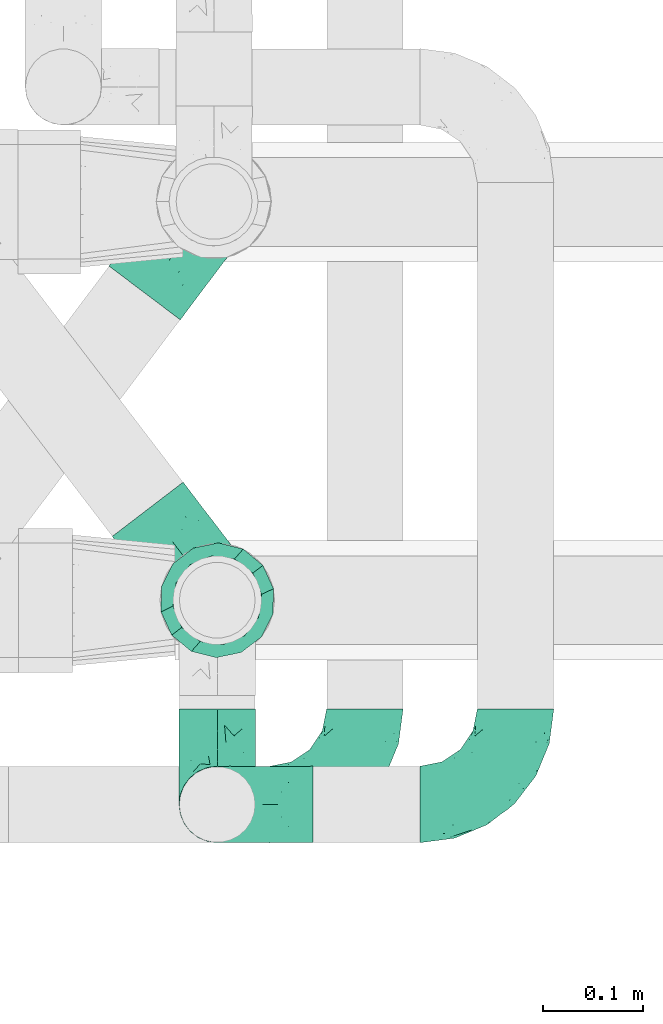
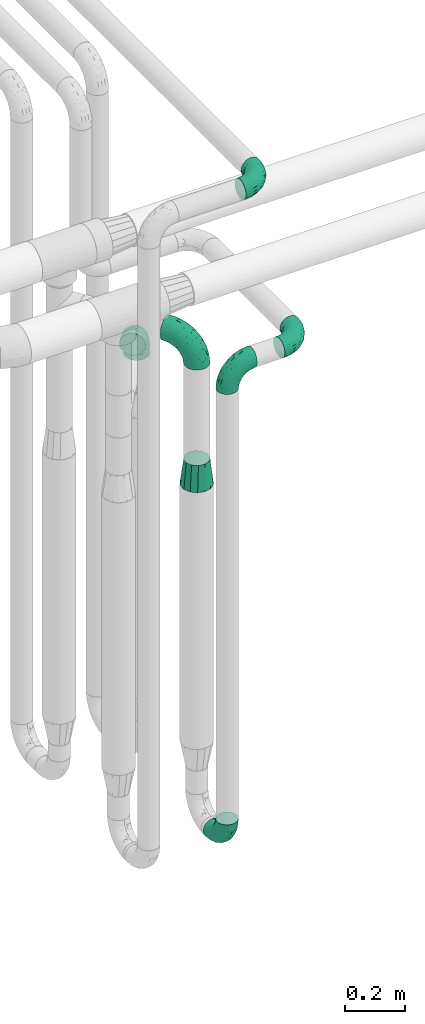
# One storey, part 657 of 827: 7 flow fittings.
"""IFC2X3 building model written with IfcOpenShell, lengths in millimetres."""

from ifc_helpers import new_model, entity, si_unit, converted_unit, derived_unit, direction, frame, origin, place, context, subcontext, project, spatial, faceted_brep, source, transform, mapped, material, type_object, type_shapes, element, save


model = new_model("IFC2X3")

# Units and contexts
model_context = context("Model", 3, precision=0.01, world=origin(), true_north=direction((6.12303176911189e-17, 1.0)))
body_context = subcontext(model_context, "Body", "Model", "MODEL_VIEW")
ifc_project = project(units=[si_unit("LENGTHUNIT", "METRE", prefix="MILLI"), si_unit("AREAUNIT", "SQUARE_METRE"), si_unit("VOLUMEUNIT", "CUBIC_METRE"), converted_unit("PLANEANGLEUNIT", "DEGREE", entity("IfcRatioMeasure", 0.0174532925199433), si_unit("PLANEANGLEUNIT", "RADIAN"), dimensions=[0, 0, 0, 0, 0, 0, 0]), si_unit("MASSUNIT", "GRAM", prefix="KILO"), derived_unit("MASSDENSITYUNIT", [(si_unit("MASSUNIT", "GRAM", prefix="KILO"), 1), (si_unit("LENGTHUNIT", "METRE"), -3)]), derived_unit("MOMENTOFINERTIAUNIT", [(si_unit("LENGTHUNIT", "METRE"), 4)]), si_unit("TIMEUNIT", "SECOND"), si_unit("FREQUENCYUNIT", "HERTZ"), si_unit("THERMODYNAMICTEMPERATUREUNIT", "DEGREE_CELSIUS"), derived_unit("THERMALTRANSMITTANCEUNIT", [(si_unit("MASSUNIT", "GRAM", prefix="KILO"), 1), (si_unit("THERMODYNAMICTEMPERATUREUNIT", "KELVIN"), -1), (si_unit("TIMEUNIT", "SECOND"), -3)]), derived_unit("VOLUMETRICFLOWRATEUNIT", [(si_unit("LENGTHUNIT", "METRE"), 3), (si_unit("TIMEUNIT", "SECOND"), -1)]), derived_unit("MASSFLOWRATEUNIT", [(si_unit("MASSUNIT", "GRAM", prefix="KILO"), 1), (si_unit("TIMEUNIT", "SECOND"), -1)]), derived_unit("ROTATIONALFREQUENCYUNIT", [(si_unit("TIMEUNIT", "SECOND"), -1)]), si_unit("ELECTRICCURRENTUNIT", "AMPERE"), si_unit("ELECTRICVOLTAGEUNIT", "VOLT"), si_unit("POWERUNIT", "WATT"), si_unit("FORCEUNIT", "NEWTON", prefix="KILO"), si_unit("ILLUMINANCEUNIT", "LUX"), si_unit("LUMINOUSFLUXUNIT", "LUMEN"), si_unit("LUMINOUSINTENSITYUNIT", "CANDELA"), derived_unit("USERDEFINED", [(si_unit("MASSUNIT", "GRAM", prefix="KILO"), -1), (si_unit("LENGTHUNIT", "METRE"), -2), (si_unit("TIMEUNIT", "SECOND"), 3), (si_unit("LUMINOUSFLUXUNIT", "LUMEN"), 1)]), derived_unit("LINEARVELOCITYUNIT", [(si_unit("LENGTHUNIT", "METRE"), 1), (si_unit("TIMEUNIT", "SECOND"), -1)]), si_unit("PRESSUREUNIT", "PASCAL"), derived_unit("USERDEFINED", [(si_unit("LENGTHUNIT", "METRE"), -2), (si_unit("MASSUNIT", "GRAM", prefix="KILO"), 1), (si_unit("TIMEUNIT", "SECOND"), -2)]), derived_unit("LINEARFORCEUNIT", [(si_unit("MASSUNIT", "GRAM", prefix="KILO"), 1), (si_unit("LENGTHUNIT", "METRE"), 1), (si_unit("TIMEUNIT", "SECOND"), -2), (si_unit("LENGTHUNIT", "METRE"), -1)]), derived_unit("PLANARFORCEUNIT", [(si_unit("MASSUNIT", "GRAM", prefix="KILO"), 1), (si_unit("LENGTHUNIT", "METRE"), 1), (si_unit("TIMEUNIT", "SECOND"), -2), (si_unit("LENGTHUNIT", "METRE"), -2)])], contexts=[model_context])

# Site, building, storey
site_placement = place(None, origin())
site = spatial("IfcSite", under=ifc_project, at=site_placement, CompositionType="ELEMENT")
building_placement = place(site_placement, origin())
building = spatial("IfcBuilding", under=site, at=building_placement, CompositionType="ELEMENT")
storey_placement = place(building_placement, frame((0.0, 0.0, 28200.0)))
storey = spatial("IfcBuildingStorey", under=building, at=storey_placement, Name="08", CompositionType="ELEMENT", Elevation=28200.0)

# Flow fittings
ifc_material = material()
pipe_fitting_type_1 = type_object("IfcPipeFittingType", Name="ADSK_1", PredefinedType="NOTDEFINED", material=ifc_material)
shared_shape_1 = source(origin(), body_context, "Body", "Brep", [
    faceted_brep([(-95.0, 19.02, -32.95), (-95.0, 9.85, -36.75), (-95.0, 0.0, -38.05), (-95.0, -9.85, -36.75), (-95.0, -19.03, -32.95), (-95.0, -26.91, -26.91), (-95.0, -32.95, -19.03), (-95.0, -36.75, -9.85), (-95.0, -38.05, 0.0), (-95.0, -36.75, 9.85), (-95.0, -32.95, 19.02), (-95.0, -26.91, 26.91), (-95.0, -19.03, 32.95), (-95.0, -9.85, 36.75), (-95.0, 0.0, 38.05), (-95.0, 9.85, 36.75), (-95.0, 19.02, 32.95), (-95.0, 26.91, 26.91), (-95.0, 32.95, 19.02), (-95.0, 36.75, 9.85), (-95.0, 38.05, 0.0), (-95.0, 36.75, -9.85), (-95.0, 32.95, -19.03), (-95.0, 26.91, -26.91), (0.0, 95.0, -38.05), (-9.85, 95.0, -36.75), (-19.02, 95.0, -32.95), (-26.91, 95.0, -26.91), (-32.95, 95.0, -19.03), (-36.75, 95.0, -9.85), (-38.05, 95.0, 0.0), (-36.75, 95.0, 9.85), (-32.95, 95.0, 19.02), (-26.91, 95.0, 26.91), (-19.02, 95.0, 32.95), (-9.85, 95.0, 36.75), (0.0, 95.0, 38.05), (9.85, 95.0, 36.75), (19.03, 95.0, 32.95), (26.91, 95.0, 26.91), (32.95, 95.0, 19.02), (36.75, 95.0, 9.85), (38.05, 95.0, 0.0), (36.75, 95.0, -9.85), (32.95, 95.0, -19.03), (26.91, 95.0, -26.91), (19.03, 95.0, -32.95), (9.85, 95.0, -36.75), (-7.99, -4.96, 6.3), (-0.92, 0.92, 0.0), (4.62, 8.1, 8.01), (-76.19, -35.57, 0.0), (-64.32, -32.32, 12.43), (20.51, 62.45, 28.68), (-60.56, -33.52, 0.0), (-70.4, -13.47, 34.42), (-39.61, -5.88, 32.32), (-49.6, 2.07, 37.1), (-70.34, -28.81, 21.71), (14.64, 40.81, 26.5), (5.88, 39.61, 32.32), (3.59, 20.77, 25.31), (-40.45, 68.06, 16.75), (-62.45, -20.51, 28.68), (-44.52, -26.87, 0.0), (-28.47, -20.22, 0.0), (-26.43, -17.83, 8.75), (-76.1, 39.63, 10.76), (-72.74, 37.58, 18.19), (-60.35, 46.18, 14.61), (-13.4, 13.4, 32.12), (-20.77, -3.59, 25.31), (-14.66, 81.47, 35.56), (-6.22, 71.26, 37.92), (-57.5, 42.48, 22.79), (-15.0, 34.74, 37.7), (-27.1, 12.08, 36.05), (-9.2, 28.81, 35.63), (-79.98, 23.7, 30.95), (-73.68, -4.3, 37.48), (-30.74, 21.67, 37.97), (-62.36, 47.59, 6.79), (-72.71, 32.83, 24.69), (-67.42, 7.02, 37.95), (-32.13, 75.27, 24.51), (-43.46, 51.47, 26.26), (-24.98, 73.15, 31.29), (20.59, 41.28, 19.85), (7.79, 16.09, 15.86), (-73.21, 42.39, 0.0), (-54.73, 54.73, 0.0), (-73.44, 15.79, 35.79), (-5.94, 4.32, 20.43), (28.81, 70.34, 21.71), (32.32, 64.32, 12.43), (-53.59, 26.2, 35.09), (-52.02, 19.31, 37.21), (21.38, 33.53, 10.34), (26.87, 44.52, 0.0), (-48.28, 12.14, 38.05), (4.3, 73.68, 37.48), (-44.08, -25.52, 12.79), (-41.28, -20.59, 19.85), (35.57, 76.19, 0.0), (-47.26, 54.3, 20.18), (-47.4, 61.99, 8.58), (-42.39, 73.21, 0.0), (-39.67, 78.86, 7.21), (-45.69, 36.84, 33.11), (-32.83, 50.13, 33.35), (13.47, 70.4, 34.42), (-18.25, 63.73, 36.07), (-40.63, -13.75, 27.22), (-16.63, 46.37, 37.95), (-53.47, 38.79, 28.59), (-26.07, 48.54, 36.15), (-34.51, 34.51, 36.86), (-2.07, 49.6, 37.1), (-22.79, -10.49, 19.23), (-61.73, 28.67, 31.87), (9.65, 14.7, 0.0), (20.22, 28.47, 0.0), (33.52, 60.56, 0.0), (-11.42, -5.44, 13.25), (-14.7, -9.65, 0.0), (-81.47, 14.66, -35.56), (-62.45, -20.51, -28.68), (-71.26, 6.22, -37.92), (-75.27, 32.13, -24.51), (-73.15, 24.98, -31.29), (13.47, 70.4, -34.42), (5.88, 39.61, -32.32), (-2.07, 49.6, -37.1), (-78.86, 39.67, -7.21), (-70.4, -13.47, -34.42), (-39.61, -5.88, -32.32), (-61.99, 47.4, -8.58), (32.32, 64.32, -12.43), (28.81, 70.34, -21.71), (-63.73, 18.25, -36.07), (-50.13, 32.83, -33.35), (4.3, 73.68, -37.48), (-7.02, 67.42, -37.95), (-39.63, 76.1, -10.76), (-46.18, 60.35, -14.61), (-47.59, 62.36, -6.79), (-64.32, -32.32, -12.43), (-26.2, 53.59, -35.09), (-15.79, 73.44, -35.79), (-19.31, 52.02, -37.21), (-37.58, 72.74, -18.19), (-70.34, -28.81, -21.71), (-42.48, 57.5, -22.79), (-38.79, 53.47, -28.59), (-51.47, 43.46, -26.26), (-32.83, 72.71, -24.69), (-46.37, 16.63, -37.95), (-73.68, -4.3, -37.48), (-41.28, -20.59, -19.85), (-44.08, -25.52, -12.79), (13.75, 40.63, -27.22), (20.51, 62.45, -28.68), (-68.06, 40.45, -16.75), (-54.3, 47.26, -20.18), (-12.14, 48.28, -38.05), (-21.67, 30.74, -37.97), (-36.84, 45.69, -33.11), (-11.42, -5.44, -13.25), (7.79, 16.09, -15.86), (4.62, 8.1, -8.01), (-23.7, 79.98, -30.95), (-26.43, -17.83, -8.75), (-7.99, -4.96, -6.3), (-40.81, -14.64, -26.5), (-20.77, -3.59, -25.31), (-34.74, 15.0, -37.7), (-12.08, 27.1, -36.05), (-28.81, 9.2, -35.63), (-22.79, -10.49, -19.23), (21.38, 33.53, -10.34), (20.59, 41.28, -19.85), (-48.54, 26.07, -36.15), (-49.6, 2.07, -37.1), (-13.4, 13.4, -32.12), (3.59, 20.77, -25.31), (-28.67, 61.73, -31.87), (-34.51, 34.51, -36.86), (-5.94, 4.32, -20.43)], [[[0, 1, 2, 3, 4, 5, 6, 7, 8, 9, 10, 11, 12, 13, 14, 15, 16, 17, 18, 19, 20, 21, 22, 23]], [[24, 25, 26, 27, 28, 29, 30, 31, 32, 33, 34, 35, 36, 37, 38, 39, 40, 41, 42, 43, 44, 45, 46, 47]], [[48, 49, 50]], [[51, 52, 9]], [[53, 39, 38]], [[9, 52, 10]], [[54, 52, 51]], [[55, 56, 57]], [[11, 10, 58]], [[59, 60, 61]], [[32, 31, 62]], [[63, 12, 11]], [[63, 55, 12]], [[64, 65, 66]], [[67, 68, 69]], [[70, 56, 71]], [[35, 72, 73]], [[69, 68, 74]], [[75, 76, 77]], [[16, 78, 17]], [[13, 79, 14]], [[76, 75, 80]], [[67, 69, 81]], [[18, 17, 82]], [[14, 79, 83]], [[20, 19, 67]], [[84, 85, 86]], [[87, 61, 88]], [[89, 81, 90]], [[18, 82, 68]], [[15, 91, 16]], [[14, 83, 15]], [[71, 92, 61]], [[17, 78, 82]], [[93, 87, 94]], [[95, 91, 96]], [[97, 98, 94]], [[86, 72, 34]], [[96, 99, 80]], [[37, 36, 100]], [[40, 39, 93]], [[40, 94, 41]], [[64, 66, 101]], [[93, 94, 40]], [[58, 102, 63]], [[94, 103, 41]], [[94, 87, 97]], [[104, 69, 74]], [[34, 33, 86]], [[105, 69, 104]], [[52, 58, 10]], [[106, 107, 30]], [[108, 109, 85]], [[105, 106, 90]], [[53, 110, 60]], [[86, 111, 72]], [[86, 109, 111]], [[33, 84, 86]], [[12, 55, 13]], [[112, 56, 63]], [[110, 38, 37]], [[34, 72, 35]], [[36, 35, 73]], [[111, 113, 73]], [[105, 107, 106]], [[110, 53, 38]], [[74, 114, 85]], [[91, 15, 83]], [[105, 90, 81]], [[107, 62, 31]], [[33, 32, 84]], [[115, 109, 116]], [[111, 115, 113]], [[100, 73, 117]], [[56, 55, 63]], [[79, 55, 57]], [[102, 118, 112]], [[56, 70, 76]], [[100, 110, 37]], [[117, 77, 60]], [[117, 60, 110]], [[60, 70, 61]], [[58, 52, 101]], [[63, 11, 58]], [[39, 53, 93]], [[87, 93, 53]], [[96, 91, 83]], [[78, 91, 119]], [[32, 62, 84]], [[84, 62, 104]], [[86, 85, 109]], [[85, 114, 108]], [[80, 113, 116]], [[117, 73, 113]], [[80, 116, 96]], [[80, 57, 76]], [[71, 112, 118]], [[61, 87, 59]], [[62, 107, 105]], [[97, 120, 121]], [[70, 71, 61]], [[71, 118, 92]], [[73, 100, 36]], [[110, 100, 117]], [[55, 79, 13]], [[83, 79, 57]], [[96, 83, 99]], [[116, 108, 95]], [[50, 97, 88]], [[97, 87, 88]], [[50, 49, 120]], [[122, 94, 98]], [[89, 20, 67]], [[105, 81, 69]], [[89, 67, 81]], [[68, 19, 18]], [[68, 67, 19]], [[74, 68, 82]], [[114, 82, 119]], [[74, 85, 104]], [[82, 114, 74]], [[114, 119, 108]], [[95, 108, 119]], [[116, 109, 108]], [[123, 48, 50]], [[97, 50, 120]], [[123, 50, 88]], [[91, 95, 119]], [[116, 95, 96]], [[84, 104, 85]], [[104, 62, 105]], [[83, 57, 99]], [[57, 80, 99]], [[66, 48, 123]], [[66, 124, 48]], [[118, 66, 123]], [[124, 66, 65]], [[66, 118, 101]], [[54, 64, 52]], [[124, 49, 48]], [[30, 107, 31]], [[91, 78, 16]], [[82, 78, 119]], [[56, 76, 57]], [[77, 76, 70]], [[60, 77, 70]], [[77, 117, 75]], [[117, 113, 75]], [[113, 80, 75]], [[9, 8, 51]], [[103, 94, 122]], [[103, 42, 41]], [[73, 72, 111]], [[113, 115, 116]], [[111, 109, 115]], [[102, 112, 63]], [[71, 56, 112]], [[118, 102, 101]], [[92, 123, 88]], [[123, 92, 118]], [[61, 92, 88]], [[87, 53, 59]], [[60, 59, 53]], [[97, 121, 98]], [[58, 101, 102]], [[64, 101, 52]], [[125, 1, 0]], [[126, 5, 4]], [[2, 1, 127]], [[1, 125, 127]], [[128, 129, 23]], [[130, 131, 132]], [[89, 133, 20]], [[126, 134, 135]], [[136, 89, 90]], [[137, 138, 44]], [[139, 129, 140]], [[24, 141, 142]], [[143, 144, 145]], [[125, 129, 139]], [[6, 146, 7]], [[147, 148, 149]], [[146, 51, 7]], [[143, 150, 144]], [[146, 6, 151]], [[152, 153, 154]], [[126, 4, 134]], [[0, 23, 129]], [[28, 155, 150]], [[43, 42, 103]], [[54, 146, 64]], [[139, 156, 127]], [[157, 3, 2]], [[151, 158, 159]], [[160, 131, 161]], [[22, 21, 162]], [[136, 144, 163]], [[149, 164, 165]], [[24, 142, 25]], [[166, 140, 154]], [[154, 129, 128]], [[143, 30, 29]], [[167, 168, 169]], [[155, 28, 27]], [[26, 170, 27]], [[171, 167, 172]], [[26, 25, 148]], [[27, 170, 155]], [[173, 135, 174]], [[144, 150, 152]], [[175, 176, 177]], [[24, 47, 141]], [[45, 161, 46]], [[148, 25, 142]], [[176, 175, 165]], [[64, 159, 171]], [[138, 45, 44]], [[130, 46, 161]], [[137, 44, 43]], [[178, 159, 158]], [[137, 103, 122]], [[163, 144, 152]], [[136, 133, 89]], [[103, 137, 43]], [[6, 5, 151]], [[178, 158, 173]], [[134, 4, 3]], [[178, 173, 174]], [[137, 98, 179]], [[145, 90, 106]], [[138, 180, 161]], [[46, 130, 47]], [[136, 90, 145]], [[133, 162, 21]], [[23, 22, 128]], [[139, 140, 181]], [[139, 181, 156]], [[157, 127, 182]], [[157, 134, 3]], [[182, 177, 135]], [[182, 135, 134]], [[135, 183, 174]], [[131, 130, 161]], [[141, 130, 132]], [[160, 180, 184]], [[131, 183, 176]], [[5, 126, 151]], [[158, 151, 126]], [[180, 138, 137]], [[161, 45, 138]], [[149, 148, 142]], [[170, 148, 185]], [[22, 162, 128]], [[128, 162, 163]], [[129, 154, 140]], [[154, 153, 166]], [[165, 156, 186]], [[182, 127, 156]], [[165, 186, 149]], [[165, 132, 176]], [[131, 184, 183]], [[187, 167, 178]], [[184, 168, 187]], [[167, 169, 172]], [[184, 180, 168]], [[174, 183, 184]], [[127, 157, 2]], [[134, 157, 182]], [[130, 141, 47]], [[142, 141, 132]], [[149, 142, 164]], [[186, 166, 147]], [[180, 179, 168]], [[169, 179, 120]], [[137, 179, 180]], [[179, 121, 120]], [[106, 30, 143]], [[136, 145, 144]], [[106, 143, 145]], [[150, 29, 28]], [[150, 143, 29]], [[152, 150, 155]], [[153, 155, 185]], [[152, 154, 163]], [[155, 153, 152]], [[153, 185, 166]], [[147, 166, 185]], [[186, 140, 166]], [[169, 120, 49]], [[169, 49, 172]], [[179, 169, 168]], [[148, 147, 185]], [[186, 147, 149]], [[128, 163, 154]], [[163, 162, 136]], [[142, 132, 164]], [[132, 165, 164]], [[171, 124, 65]], [[124, 171, 172]], [[64, 146, 159]], [[171, 159, 178]], [[171, 65, 64]], [[172, 49, 124]], [[162, 133, 136]], [[20, 133, 21]], [[148, 170, 26]], [[155, 170, 185]], [[131, 176, 132]], [[177, 176, 183]], [[135, 177, 183]], [[177, 182, 175]], [[182, 156, 175]], [[156, 165, 175]], [[51, 146, 54]], [[51, 8, 7]], [[129, 125, 0]], [[127, 125, 139]], [[140, 186, 181]], [[156, 181, 186]], [[158, 126, 173]], [[135, 173, 126]], [[187, 178, 174]], [[171, 178, 167]], [[184, 187, 174]], [[167, 187, 168]], [[180, 160, 161]], [[184, 131, 160]], [[98, 137, 122]], [[98, 121, 179]], [[151, 159, 146]]]),
])
type_shapes(pipe_fitting_type_1, [shared_shape_1])
flow_fitting_1_placement = place(storey_placement, frame((44045.03, 13686.84, 3000.0)))
element("IfcFlowFitting", 1, at=flow_fitting_1_placement, inside=storey, type_object=pipe_fitting_type_1, material=ifc_material, Name="ADSK_1", ObjectType="ADSK_1", context=body_context, shape_type="MappedRepresentation", body=[
    mapped(shared_shape_1, transform((0.0, 0.0, 0.0), scale=1.0)),
])
for number, where, z_axis, x_axis, name in (
    (2, (43898.22, 13686.98, 350.0), (-1.0, 0.0, 0.0), (0.0, -1.0, 0.0), "ADSK_1"),
    (3, (43898.22, 13686.98, 2300.0), (0.0, 1.0, 0.0), (0.0, 0.0, 1.0), "ADSK_1"),
):
    element("IfcFlowFitting", number, at=place(storey_placement, frame(where, z_axis=z_axis, x_axis=x_axis)), inside=storey, type_object=pipe_fitting_type_1, material=ifc_material, Name=name, ObjectType="ADSK_1", context=body_context, shape_type="MappedRepresentation", body=[
        mapped(shared_shape_1, transform((0.0, 0.0, 0.0), scale=1.0)),
    ])
flow_fitting_2_placement = place(storey_placement, frame((44195.03, 13686.98, 2300.0)))
element("IfcFlowFitting", 4, at=flow_fitting_2_placement, inside=storey, type_object=pipe_fitting_type_1, material=ifc_material, Name="ADSK_1", ObjectType="ADSK_1", context=body_context, shape_type="MappedRepresentation", body=[
    mapped(shared_shape_1, transform((0.0, 0.0, 0.0), scale=1.0)),
])
pipe_fitting_type_2 = type_object("IfcPipeFittingType", Name="ADSK_1", PredefinedType="NOTDEFINED", material=ifc_material)
shared_shape_2 = source(origin(), body_context, "Body", "Brep", [
    faceted_brep([(-114.0, 22.22, -38.49), (-114.0, 11.5, -42.94), (-114.0, 0.0, -44.45), (-114.0, -11.5, -42.94), (-114.0, -22.23, -38.49), (-114.0, -31.43, -31.43), (-114.0, -38.49, -22.23), (-114.0, -42.94, -11.5), (-114.0, -44.45, 0.0), (-114.0, -42.94, 11.5), (-114.0, -38.49, 22.22), (-114.0, -31.43, 31.43), (-114.0, -22.23, 38.49), (-114.0, -11.5, 42.94), (-114.0, 0.0, 44.45), (-114.0, 11.5, 42.94), (-114.0, 22.22, 38.49), (-114.0, 31.43, 31.43), (-114.0, 38.49, 22.22), (-114.0, 42.94, 11.5), (-114.0, 44.45, 0.0), (-114.0, 42.94, -11.5), (-114.0, 38.49, -22.23), (-114.0, 31.43, -31.43), (0.0, 114.0, -44.45), (-11.5, 114.0, -42.94), (-22.22, 114.0, -38.49), (-31.43, 114.0, -31.43), (-38.49, 114.0, -22.23), (-42.94, 114.0, -11.5), (-44.45, 114.0, 0.0), (-42.94, 114.0, 11.5), (-38.49, 114.0, 22.22), (-31.43, 114.0, 31.43), (-22.22, 114.0, 38.49), (-11.5, 114.0, 42.94), (0.0, 114.0, 44.45), (11.5, 114.0, 42.94), (22.23, 114.0, 38.49), (31.43, 114.0, 31.43), (38.49, 114.0, 22.22), (42.94, 114.0, 11.5), (44.45, 114.0, 0.0), (42.94, 114.0, -11.5), (38.49, 114.0, -22.23), (31.43, 114.0, -31.43), (22.23, 114.0, -38.49), (11.5, 114.0, -42.94), (-24.5, -15.82, 8.24), (-7.18, -2.06, 7.97), (-13.53, -4.79, 15.72), (-92.03, -41.56, 0.0), (-77.08, -37.56, 14.57), (23.74, 74.96, 33.55), (-72.99, -39.05, 0.0), (-84.56, -15.6, 40.23), (-47.88, -6.37, 37.83), (-59.8, 2.77, 43.37), (-84.46, -33.54, 25.41), (16.69, 49.28, 31.02), (6.37, 47.88, 37.83), (3.35, 25.47, 29.77), (-47.43, 81.55, 19.51), (-74.96, -23.74, 33.55), (-46.77, -27.89, 11.23), (-53.88, -31.14, 0.0), (-87.05, 38.52, 28.81), (-63.44, 55.78, 24.79), (-93.24, 43.37, 18.58), (-16.67, 16.67, 37.64), (-25.47, -3.35, 29.77), (-17.2, 97.7, 41.53), (-7.42, 85.54, 44.3), (-67.09, 46.29, 31.23), (-18.08, 42.1, 44.06), (-32.93, 14.9, 42.17), (-11.54, 34.94, 41.69), (-95.7, 27.79, 36.14), (-88.55, -4.92, 43.79), (-2.77, 59.8, 43.37), (-87.65, 48.44, 9.87), (-81.01, 8.37, 44.32), (-37.63, 90.26, 28.6), (-51.29, 61.56, 30.59), (-29.32, 87.72, 36.52), (23.49, 49.5, 23.28), (8.19, 20.11, 19.18), (-70.06, 58.9, 9.01), (-87.38, 49.74, 0.0), (-88.15, 18.57, 41.8), (-7.96, 6.22, 24.33), (33.54, 84.46, 25.41), (37.56, 77.08, 14.57), (-58.37, 34.98, 40.92), (-62.38, 23.02, 43.45), (24.15, 39.93, 12.16), (31.14, 53.88, 0.0), (-58.13, 14.61, 44.45), (-37.17, 26.09, 44.37), (4.92, 88.55, 43.79), (-34.77, -23.22, 0.0), (-49.5, -23.49, 23.28), (41.56, 92.03, 0.0), (-57.83, 66.03, 19.12), (-71.84, 54.46, 17.06), (-46.46, 94.23, 8.51), (-49.74, 87.38, 0.0), (-38.96, 59.98, 38.88), (-55.29, 46.95, 36.83), (-64.82, 64.82, 0.0), (-55.88, 73.75, 10.01), (15.6, 84.56, 40.23), (-21.6, 76.38, 42.11), (-49.04, -15.53, 31.95), (-19.97, 55.59, 44.33), (-73.61, 33.95, 37.2), (-31.05, 58.14, 42.19), (-41.3, 41.3, 43.02), (-27.36, -11.22, 22.61), (9.28, 15.84, 8.73), (23.22, 34.77, 0.0), (39.05, 72.99, 0.0), (-1.96, 1.96, 0.0), (10.63, 18.37, 0.0), (-18.37, -10.63, 0.0), (-97.7, 17.2, -41.53), (9.28, 15.84, -8.73), (-13.53, -4.79, -15.72), (8.19, 20.11, -19.18), (-85.54, 7.42, -44.3), (-8.37, 81.01, -44.32), (-90.26, 37.63, -28.6), (-87.72, 29.32, -36.52), (-27.79, 95.7, -36.14), (-38.52, 87.05, -28.81), (-94.23, 46.46, -8.51), (-84.56, -15.6, -40.23), (-73.75, 55.88, -10.01), (-10.19, -4.86, -7.51), (-76.38, 21.6, -42.11), (-59.98, 38.96, -38.88), (-49.28, -16.69, -31.02), (-47.88, -6.37, -37.83), (-25.47, -3.35, -29.77), (-34.98, 58.37, -40.92), (-46.95, 55.29, -36.83), (-77.08, -37.56, -14.57), (-18.57, 88.15, -41.8), (-23.02, 62.38, -43.45), (-55.78, 63.44, -24.79), (-43.37, 93.24, -18.58), (-84.46, -33.54, -25.41), (-33.95, 73.61, -37.2), (-46.29, 67.09, -31.23), (-74.96, -23.74, -33.55), (-48.44, 87.65, -9.87), (-45.44, -27.06, -11.87), (-88.55, -4.92, -43.79), (-49.5, -23.49, -23.28), (-14.61, 58.13, -44.45), (-26.09, 37.17, -44.37), (15.6, 84.56, -40.23), (6.37, 47.88, -37.83), (-2.77, 59.8, -43.37), (-81.55, 47.43, -19.51), (33.54, 84.46, -25.41), (23.49, 49.5, -23.28), (23.74, 74.96, -33.55), (-42.1, 18.08, -44.06), (-14.9, 32.93, -42.17), (-34.94, 11.54, -41.69), (-61.56, 51.29, -30.59), (-27.36, -11.22, -22.61), (37.56, 77.08, -14.57), (4.92, 88.55, -43.79), (-59.8, 2.77, -43.37), (-66.03, 57.83, -19.12), (-54.46, 71.84, -17.06), (-55.59, 19.97, -44.33), (-58.9, 70.06, -9.01), (24.15, 39.93, -12.16), (15.53, 49.04, -31.95), (-58.14, 31.05, -42.19), (-41.3, 41.3, -43.02), (-16.67, 16.67, -37.64), (3.35, 25.47, -29.77), (-7.96, 6.22, -24.33), (-26.36, -16.33, -11.05)], [[[0, 1, 2, 3, 4, 5, 6, 7, 8, 9, 10, 11, 12, 13, 14, 15, 16, 17, 18, 19, 20, 21, 22, 23]], [[24, 25, 26, 27, 28, 29, 30, 31, 32, 33, 34, 35, 36, 37, 38, 39, 40, 41, 42, 43, 44, 45, 46, 47]], [[48, 49, 50]], [[51, 52, 9]], [[53, 39, 38]], [[9, 52, 10]], [[54, 52, 51]], [[55, 56, 57]], [[11, 10, 58]], [[59, 60, 61]], [[32, 31, 62]], [[63, 12, 11]], [[63, 55, 12]], [[64, 52, 65]], [[66, 67, 68]], [[69, 56, 70]], [[35, 71, 72]], [[67, 66, 73]], [[74, 75, 76]], [[16, 77, 17]], [[13, 78, 14]], [[76, 79, 74]], [[68, 80, 19]], [[18, 17, 66]], [[14, 78, 81]], [[20, 19, 80]], [[82, 83, 84]], [[85, 61, 86]], [[87, 88, 80]], [[18, 68, 19]], [[15, 89, 16]], [[14, 81, 15]], [[70, 90, 61]], [[17, 77, 66]], [[91, 85, 92]], [[93, 89, 94]], [[95, 96, 92]], [[84, 71, 34]], [[94, 97, 98]], [[37, 36, 99]], [[40, 39, 91]], [[40, 92, 41]], [[65, 100, 64]], [[91, 92, 40]], [[58, 101, 63]], [[92, 102, 41]], [[92, 85, 95]], [[67, 103, 104]], [[34, 33, 84]], [[105, 62, 31]], [[52, 58, 10]], [[106, 105, 30]], [[93, 107, 108]], [[106, 109, 110]], [[53, 111, 60]], [[84, 112, 71]], [[84, 107, 112]], [[33, 82, 84]], [[12, 55, 13]], [[113, 56, 63]], [[111, 38, 37]], [[34, 71, 35]], [[36, 35, 72]], [[112, 114, 72]], [[110, 105, 106]], [[111, 53, 38]], [[115, 108, 73]], [[89, 15, 81]], [[104, 87, 80]], [[110, 87, 103]], [[33, 32, 82]], [[116, 107, 117]], [[112, 116, 114]], [[99, 72, 79]], [[56, 55, 63]], [[78, 55, 57]], [[101, 118, 113]], [[56, 69, 75]], [[99, 111, 37]], [[79, 76, 60]], [[79, 60, 111]], [[60, 69, 61]], [[101, 58, 52]], [[63, 11, 58]], [[39, 53, 91]], [[85, 91, 53]], [[94, 89, 81]], [[77, 89, 115]], [[84, 83, 107]], [[93, 108, 115]], [[98, 114, 117]], [[79, 72, 114]], [[98, 117, 94]], [[98, 57, 75]], [[32, 62, 82]], [[83, 82, 62]], [[70, 113, 118]], [[61, 85, 59]], [[48, 64, 100]], [[95, 119, 120]], [[69, 70, 61]], [[70, 118, 90]], [[72, 99, 36]], [[111, 99, 79]], [[55, 78, 13]], [[81, 78, 57]], [[94, 81, 97]], [[93, 94, 117]], [[66, 68, 18]], [[80, 68, 104]], [[103, 87, 104]], [[80, 88, 20]], [[50, 49, 119]], [[95, 85, 86]], [[119, 95, 86]], [[121, 92, 96]], [[50, 119, 86]], [[119, 122, 123, 120]], [[110, 109, 87]], [[88, 87, 109]], [[62, 105, 110]], [[30, 105, 31]], [[81, 57, 97]], [[57, 98, 97]], [[107, 93, 117]], [[89, 93, 115]], [[107, 83, 108]], [[73, 108, 83]], [[67, 73, 83]], [[115, 73, 66]], [[103, 83, 62]], [[67, 104, 68]], [[83, 103, 67]], [[110, 103, 62]], [[89, 77, 16]], [[66, 77, 115]], [[56, 75, 57]], [[76, 75, 69]], [[60, 76, 69]], [[79, 114, 74]], [[114, 98, 74]], [[75, 74, 98]], [[9, 8, 51]], [[102, 92, 121]], [[102, 42, 41]], [[72, 71, 112]], [[52, 54, 65]], [[64, 48, 118]], [[101, 52, 64]], [[124, 122, 49]], [[118, 48, 50]], [[49, 48, 124]], [[119, 49, 122]], [[48, 100, 124]], [[114, 116, 117]], [[112, 107, 116]], [[101, 113, 63]], [[70, 56, 113]], [[64, 118, 101]], [[90, 50, 86]], [[50, 90, 118]], [[61, 90, 86]], [[85, 53, 59]], [[60, 59, 53]], [[95, 120, 96]], [[125, 1, 0]], [[126, 127, 128]], [[2, 1, 129]], [[24, 130, 25]], [[131, 132, 23]], [[27, 133, 134]], [[88, 135, 20]], [[136, 4, 3]], [[88, 109, 137]], [[138, 122, 124]], [[139, 132, 140]], [[141, 142, 143]], [[144, 140, 145]], [[125, 132, 139]], [[6, 146, 7]], [[144, 147, 148]], [[146, 51, 7]], [[134, 149, 150]], [[146, 6, 151]], [[152, 145, 153]], [[154, 4, 136]], [[154, 136, 142]], [[150, 155, 29]], [[43, 42, 102]], [[65, 146, 156]], [[0, 23, 132]], [[157, 3, 2]], [[146, 151, 158]], [[148, 159, 160]], [[161, 162, 163]], [[135, 164, 21]], [[165, 166, 167]], [[168, 169, 170]], [[147, 25, 130]], [[171, 132, 131]], [[155, 30, 29]], [[172, 141, 143]], [[134, 28, 27]], [[149, 134, 153]], [[173, 165, 44]], [[26, 25, 147]], [[22, 21, 164]], [[24, 174, 130]], [[133, 27, 26]], [[170, 175, 168]], [[24, 47, 174]], [[45, 167, 46]], [[28, 150, 29]], [[1, 125, 129]], [[156, 100, 65]], [[165, 45, 44]], [[161, 46, 167]], [[173, 44, 43]], [[6, 5, 151]], [[173, 102, 121]], [[137, 135, 88]], [[46, 161, 47]], [[102, 173, 43]], [[149, 176, 177]], [[172, 158, 141]], [[139, 178, 129]], [[154, 5, 4]], [[156, 146, 158]], [[106, 155, 179]], [[173, 96, 180]], [[181, 162, 167]], [[177, 179, 155]], [[137, 179, 176]], [[23, 22, 131]], [[182, 140, 183]], [[139, 182, 178]], [[157, 129, 175]], [[157, 136, 3]], [[175, 170, 142]], [[175, 142, 136]], [[142, 184, 143]], [[162, 161, 167]], [[174, 161, 163]], [[181, 166, 185]], [[162, 184, 169]], [[5, 154, 151]], [[158, 151, 154]], [[166, 165, 173]], [[167, 45, 165]], [[148, 147, 130]], [[133, 147, 152]], [[132, 171, 140]], [[144, 145, 152]], [[160, 178, 183]], [[175, 129, 178]], [[160, 183, 148]], [[160, 163, 169]], [[22, 164, 131]], [[171, 131, 164]], [[162, 185, 184]], [[186, 127, 172]], [[185, 128, 186]], [[156, 187, 100]], [[185, 166, 128]], [[143, 184, 185]], [[129, 157, 2]], [[136, 157, 175]], [[161, 174, 47]], [[130, 174, 163]], [[148, 130, 159]], [[144, 148, 183]], [[134, 150, 28]], [[155, 150, 177]], [[176, 179, 177]], [[155, 106, 30]], [[166, 180, 128]], [[128, 180, 126]], [[173, 180, 166]], [[126, 120, 123, 122]], [[120, 126, 180]], [[122, 138, 126]], [[137, 109, 179]], [[106, 179, 109]], [[164, 135, 137]], [[20, 135, 21]], [[130, 163, 159]], [[163, 160, 159]], [[140, 144, 183]], [[147, 144, 152]], [[140, 171, 145]], [[153, 145, 171]], [[149, 153, 171]], [[152, 153, 134]], [[176, 171, 164]], [[149, 177, 150]], [[171, 176, 149]], [[137, 176, 164]], [[147, 133, 26]], [[134, 133, 152]], [[162, 169, 163]], [[170, 169, 184]], [[142, 170, 184]], [[175, 178, 168]], [[178, 160, 168]], [[169, 168, 160]], [[51, 146, 54]], [[51, 8, 7]], [[132, 125, 0]], [[129, 125, 139]], [[156, 158, 172]], [[65, 54, 146]], [[178, 182, 183]], [[139, 140, 182]], [[158, 154, 141]], [[142, 141, 154]], [[186, 172, 143]], [[172, 127, 187]], [[185, 186, 143]], [[127, 186, 128]], [[187, 127, 138]], [[124, 100, 187]], [[126, 138, 127]], [[187, 138, 124]], [[172, 187, 156]], [[166, 181, 167]], [[185, 162, 181]], [[96, 173, 121]], [[96, 120, 180]]]),
])
type_shapes(pipe_fitting_type_2, [shared_shape_2])
for number, where, z_axis, x_axis, name in (
    (5, (43894.55, 14286.99, 2100.0), (0.798635510047293, -0.601815023152049, 0.0), (0.0, 0.0, 1.0), "ADSK_1"),
    (6, (43898.22, 13890.17, 2300.0), (-0.794341681216586, -0.607471228521984, 0.0), (0.0, 0.0, 1.0), "ADSK_1"),
):
    element("IfcFlowFitting", number, at=place(storey_placement, frame(where, z_axis=z_axis, x_axis=x_axis)), inside=storey, type_object=pipe_fitting_type_2, material=ifc_material, Name=name, ObjectType="ADSK_1", context=body_context, shape_type="MappedRepresentation", body=[
        mapped(shared_shape_2, transform((0.0, 0.0, 0.0), scale=1.0)),
    ])
pipe_fitting_type_3 = type_object("IfcPipeFittingType", Name="ADSK_1", PredefinedType="NOTDEFINED", material=ifc_material)
shared_shape_3 = source(origin(), body_context, "Body", "Brep", [
    faceted_brep([(102.0, -57.15, 0.0), (102.0, -54.32, -12.4), (102.0, -51.49, -24.8), (102.0, -43.56, -34.74), (102.0, -35.63, -44.68), (102.0, -24.17, -50.2), (102.0, -12.72, -55.72), (102.0, 0.0, -55.72), (102.0, 12.72, -55.72), (102.0, 24.17, -50.2), (102.0, 35.63, -44.68), (102.0, 43.56, -34.74), (102.0, 51.49, -24.8), (102.0, 54.32, -12.4), (102.0, 57.15, 0.0), (102.0, 54.32, 12.4), (102.0, 51.49, 24.8), (102.0, 43.56, 34.74), (102.0, 35.63, 44.68), (102.0, 24.17, 50.2), (102.0, 12.72, 55.72), (102.0, 0.0, 55.72), (102.0, -12.72, 55.72), (102.0, -24.17, 50.2), (102.0, -35.63, 44.68), (102.0, -43.56, 34.74), (102.0, -51.49, 24.8), (102.0, -54.32, 12.4), (0.0, -38.49, -22.22), (0.0, -41.47, -11.11), (0.0, -44.45, 0.0), (0.0, -41.47, 11.11), (0.0, -38.49, 22.23), (0.0, -30.36, 30.36), (0.0, -22.23, 38.49), (0.0, -11.11, 41.47), (0.0, 0.0, 44.45), (0.0, 11.11, 41.47), (0.0, 22.23, 38.49), (0.0, 30.36, 30.36), (0.0, 38.49, 22.23), (0.0, 41.47, 11.11), (0.0, 44.45, 0.0), (0.0, 41.47, -11.11), (0.0, 38.49, -22.23), (0.0, 30.36, -30.36), (0.0, 22.22, -38.49), (0.0, 11.11, -41.47), (0.0, 0.0, -44.45), (0.0, -11.11, -41.47), (0.0, -22.23, -38.49), (0.0, -30.36, -30.36)], [[[0, 1, 2, 3, 4, 5, 6, 7, 8, 9, 10, 11, 12, 13, 14, 15, 16, 17, 18, 19, 20, 21, 22, 23, 24, 25, 26, 27]], [[28, 29, 30, 31, 32, 33, 34, 35, 36, 37, 38, 39, 40, 41, 42, 43, 44, 45, 46, 47, 48, 49, 50, 51]], [[28, 2, 29]], [[11, 10, 45]], [[11, 44, 12]], [[3, 2, 28]], [[30, 29, 1]], [[42, 13, 43]], [[30, 1, 0]], [[46, 10, 9]], [[48, 8, 7, 6]], [[28, 51, 3]], [[29, 2, 1]], [[47, 46, 9]], [[5, 4, 50]], [[51, 4, 3]], [[8, 48, 47]], [[13, 42, 14]], [[51, 50, 4]], [[8, 47, 9]], [[5, 49, 6]], [[44, 11, 45]], [[43, 12, 44]], [[10, 46, 45]], [[49, 5, 50]], [[49, 48, 6]], [[13, 12, 43]], [[40, 16, 41]], [[25, 24, 33]], [[25, 32, 26]], [[17, 16, 40]], [[42, 41, 15]], [[30, 27, 31]], [[42, 15, 14]], [[34, 24, 23]], [[36, 22, 21, 20]], [[40, 39, 17]], [[41, 16, 15]], [[35, 34, 23]], [[19, 18, 38]], [[39, 18, 17]], [[22, 36, 35]], [[27, 30, 0]], [[39, 38, 18]], [[22, 35, 23]], [[19, 37, 20]], [[32, 25, 33]], [[31, 26, 32]], [[24, 34, 33]], [[37, 19, 38]], [[37, 36, 20]], [[27, 26, 31]]]),
])
type_shapes(pipe_fitting_type_3, [shared_shape_3])
flow_fitting_3_placement = place(storey_placement, frame((43898.22, 13890.17, 1795.2), z_axis=(0.607471228521984, -0.794341681216586, 0.0), x_axis=(0.0, 0.0, -1.0)))
element("IfcFlowFitting", 7, at=flow_fitting_3_placement, inside=storey, type_object=pipe_fitting_type_3, material=ifc_material, Name="ADSK_1", ObjectType="ADSK_1", context=body_context, shape_type="MappedRepresentation", body=[
    mapped(shared_shape_3, transform((0.0, 0.0, 0.0), scale=1.0)),
])

save(model, "model.ifc")
